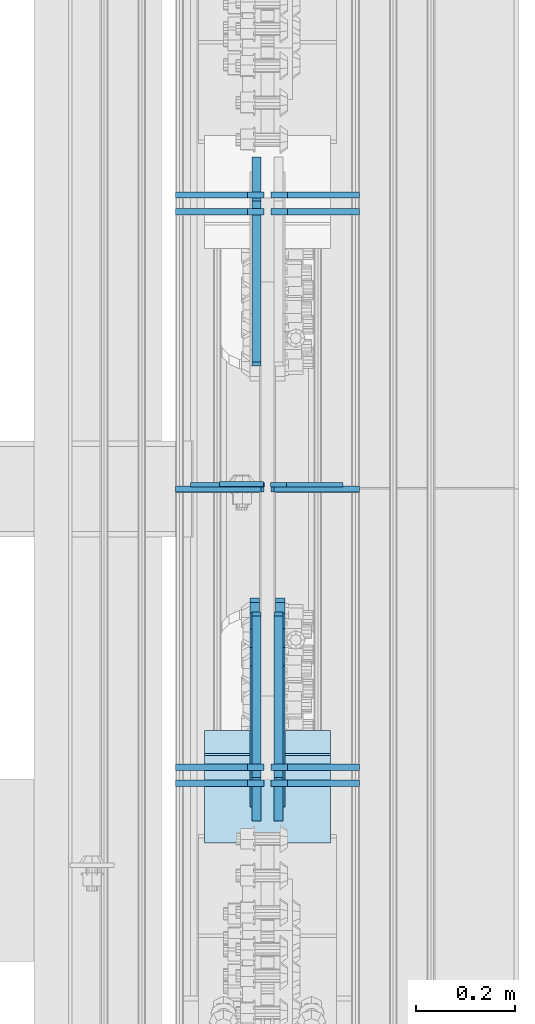
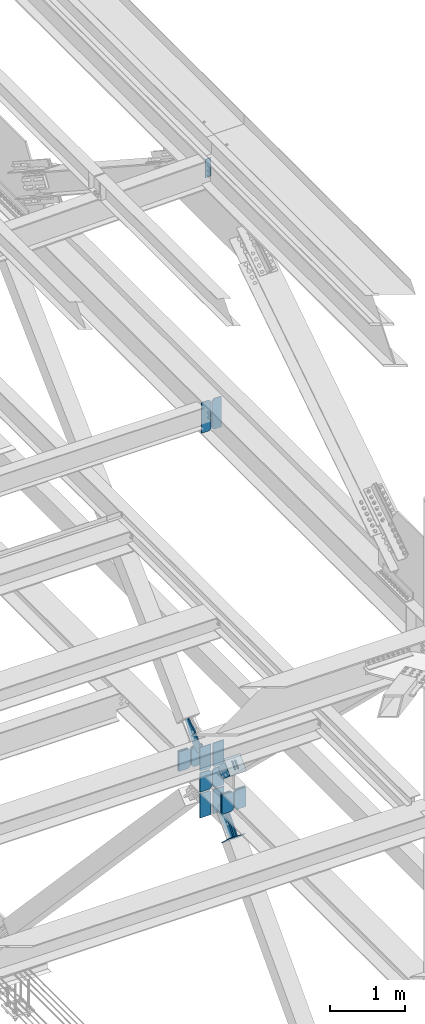
# One storey, part 3639 of 3843: 24 plates, 10 elements without a shape of their own.
"""IFC2X3 building model written with IfcOpenShell, lengths in millimetres."""

from ifc_helpers import new_model, si_unit, frame, origin_with_axes, place, context, subcontext, project, spatial, faceted_brep, material, type_object, element, aggregate, save


model = new_model("IFC2X3")

# Units and contexts
model_context = context("Model", 3, precision=1e-05, world=origin_with_axes())
body_context = subcontext(model_context, "Body", "Model", "MODEL_VIEW")
ifc_project = project(units=[si_unit("LENGTHUNIT", "METRE", prefix="MILLI"), si_unit("AREAUNIT", "SQUARE_METRE"), si_unit("VOLUMEUNIT", "CUBIC_METRE"), si_unit("MASSUNIT", "GRAM", prefix="KILO"), si_unit("TIMEUNIT", "SECOND"), si_unit("PLANEANGLEUNIT", "RADIAN"), si_unit("SOLIDANGLEUNIT", "STERADIAN"), si_unit("THERMODYNAMICTEMPERATUREUNIT", "DEGREE_CELSIUS"), si_unit("LUMINOUSINTENSITYUNIT", "LUMEN")], contexts=[model_context])

# Site, building, storey
site_placement = place(None, origin_with_axes())
site = spatial("IfcSite", under=ifc_project, at=site_placement, CompositionType="ELEMENT")
building_placement = place(site_placement, origin_with_axes())
building = spatial("IfcBuilding", under=site, at=building_placement, Name="Undefined", CompositionType="ELEMENT")
storey_placement = place(building_placement, origin_with_axes())
storey = spatial("IfcBuildingStorey", under=building, at=storey_placement, Name="Undefined", CompositionType="ELEMENT", Elevation=0.0)

# Assembly, plate
assembly_1_placement = place(storey_placement, origin_with_axes())
assembly_1 = element("IfcElementAssembly", 1, at=assembly_1_placement, inside=storey, Name="BEAM", AssemblyPlace="NOTDEFINED", PredefinedType="RIGID_FRAME")
ifc_material_1 = material(Name="STEEL/A572-50")
plate_type_1 = type_object("IfcPlateType", PredefinedType="NOTDEFINED")
plate_1_placement = place(assembly_1_placement, frame((85640.8624999999, 98397.21875, 46404.6717282419), z_axis=(-1.0, 0.0, 0.0), x_axis=(0.0, 0.0, -1.0)))
plate_1 = element("IfcPlate", 2, at=plate_1_placement, type_object=plate_type_1, material=ifc_material_1, Name="PLATE", context=body_context, shape_type="Brep", body=[
    faceted_brep([(0.0, -4.76249999999709, 0.0), (0.0, -4.76249999999709, 88.9000015258789), (0.0, 4.76249999999709, 88.9000015258789), (0.0, 4.76249999999709, 0.0), (304.800000000003, -4.76249999999709, 88.8999999999942), (304.800000000003, 4.76249999999709, 88.8999999999942), (304.800000000003, -4.76249999999709, 0.0), (304.800000000003, 4.76249999999709, 0.0)], [[[0, 1, 2, 3]], [[1, 4, 5, 2]], [[4, 6, 7, 5]], [[6, 0, 3, 7]], [[5, 7, 3, 2]], [[6, 4, 1, 0]]]),
])
aggregate(assembly_1, [plate_1])

assembly_2_placement = place(storey_placement, origin_with_axes())
assembly_2 = element("IfcElementAssembly", 3, at=assembly_2_placement, inside=storey, Name="BEAM", AssemblyPlace="NOTDEFINED", PredefinedType="RIGID_FRAME")
plate_type_2 = type_object("IfcPlateType", PredefinedType="NOTDEFINED")
plate_2_placement = place(assembly_2_placement, frame((85642.45, 98395.6318667901, 41946.5125), z_axis=(0.0, 0.0, 1.0), x_axis=(-1.0, 0.0, 0.0)))
plate_2 = element("IfcPlate", 4, at=plate_2_placement, type_object=plate_type_2, material=ifc_material_1, Name="PLATE", context=body_context, shape_type="Brep", body=[
    faceted_brep([(0.0, -4.76249999999709, 31.75), (0.0, -4.76250000000073, 469.900000000001), (0.0, 4.76250000000073, 469.900000000001), (0.0, 4.76249999999709, 31.75), (31.75, -4.76250000000073, 501.650000000001), (31.75, 4.76250000000073, 501.650000000001), (149.224999999991, -4.76250000000073, 501.650000000001), (149.224999999991, 4.76250000000073, 501.650000000001), (149.224999999977, -4.76249999999709, 0.0), (149.224999999977, 4.76249999999709, 0.0), (31.75, -4.76249999999709, 0.0), (31.75, 4.76249999999709, 0.0)], [[[0, 1, 2, 3]], [[1, 4, 5, 2]], [[4, 6, 7, 5]], [[6, 8, 9, 7]], [[8, 10, 11, 9]], [[10, 0, 3, 11]], [[5, 7, 9, 11, 3, 2]], [[10, 8, 6, 4, 1, 0]]]),
])

# Assembly, plates
assembly_3_placement = place(storey_placement, origin_with_axes())
assembly_3 = element("IfcElementAssembly", 5, at=assembly_3_placement, inside=storey, Name="BEAM", AssemblyPlace="NOTDEFINED", PredefinedType="RIGID_FRAME")
plate_type_3 = type_object("IfcPlateType", PredefinedType="NOTDEFINED")
plate_3_placement = place(assembly_3_placement, frame((85641.65625, 97792.7129254017, 36093.4), z_axis=(-1.0, 0.0, 0.0), x_axis=(0.0, 0.0, 1.0)))
plate_3 = element("IfcPlate", 6, at=plate_3_placement, type_object=plate_type_3, material=ifc_material_1, Name="CB_BEAM", context=body_context, shape_type="Brep", body=[
    faceted_brep([(0.0, -6.34999999999854, 33.3375015258789), (0.0, -6.34999999999854, 178.59375), (0.0, 6.34999999999854, 178.59375), (0.0, 6.34999999999854, 33.3375015258789), (317.499999999985, -6.34999999999854, 178.59375), (317.499999999985, 6.34999999999854, 178.59375), (317.499999999985, -6.34999999999854, 33.3375015258789), (317.499999999985, 6.34999999999854, 33.3375015258789), (284.162498474107, -6.34999999999854, 0.0), (284.162498474107, 6.34999999999854, 0.0), (33.3375015258789, -6.34999999999854, 0.0), (33.3375015258789, 6.34999999999854, 0.0)], [[[0, 1, 2, 3]], [[1, 4, 5, 2]], [[4, 6, 7, 5]], [[6, 8, 9, 7]], [[8, 10, 11, 9]], [[10, 0, 3, 11]], [[5, 7, 9, 11, 3, 2]], [[10, 8, 6, 4, 1, 0]]]),
])
plate_4_placement = place(assembly_3_placement, frame((85655.94375, 97792.7129254017, 36093.4), z_axis=(1.0, 0.0, 0.0), x_axis=(0.0, 0.0, 1.0)))
plate_4 = element("IfcPlate", 7, at=plate_4_placement, type_object=plate_type_3, material=ifc_material_1, Name="CB_BEAM", context=body_context, shape_type="Brep", body=[
    faceted_brep([(0.0, -6.34999999999854, 33.3375015258789), (0.0, -6.34999999999854, 178.59375), (0.0, 6.34999999999854, 178.59375), (0.0, 6.34999999999854, 33.3375015258789), (317.499999999985, -6.34999999999854, 178.59375), (317.499999999985, 6.34999999999854, 178.59375), (317.499999999985, -6.34999999999854, 33.3375015258789), (317.499999999985, 6.34999999999854, 33.3375015258789), (284.162498474107, -6.34999999999854, 0.0), (284.162498474107, 6.34999999999854, 0.0), (33.3375015258789, -6.34999999999854, 0.0), (33.3375015258789, 6.34999999999854, 0.0)], [[[0, 1, 2, 3]], [[1, 4, 5, 2]], [[4, 6, 7, 5]], [[6, 8, 9, 7]], [[8, 10, 11, 9]], [[10, 0, 3, 11]], [[5, 7, 9, 11, 3, 2]], [[10, 8, 6, 4, 1, 0]]]),
])
plate_5_placement = place(assembly_3_placement, frame((85641.65625, 97824.7372978455, 36093.4), z_axis=(-1.0, 0.0, 0.0), x_axis=(0.0, 0.0, 1.0)))
plate_5 = element("IfcPlate", 8, at=plate_5_placement, type_object=plate_type_3, material=ifc_material_1, Name="CB_BEAM", context=body_context, shape_type="Brep", body=[
    faceted_brep([(0.0, -6.34999999999854, 33.3375015258789), (0.0, -6.34999999999854, 178.59375), (0.0, 6.34999999999854, 178.59375), (0.0, 6.34999999999854, 33.3375015258789), (317.499999999985, -6.34999999999854, 178.59375), (317.499999999985, 6.34999999999854, 178.59375), (317.499999999985, -6.34999999999854, 33.3375015258789), (317.499999999985, 6.34999999999854, 33.3375015258789), (284.162498474107, -6.34999999999854, 0.0), (284.162498474107, 6.34999999999854, 0.0), (33.3375015258789, -6.34999999999854, 0.0), (33.3375015258789, 6.34999999999854, 0.0)], [[[0, 1, 2, 3]], [[1, 4, 5, 2]], [[4, 6, 7, 5]], [[6, 8, 9, 7]], [[8, 10, 11, 9]], [[10, 0, 3, 11]], [[5, 7, 9, 11, 3, 2]], [[10, 8, 6, 4, 1, 0]]]),
])
plate_6_placement = place(assembly_3_placement, frame((85655.94375, 97824.7372978455, 36093.4), z_axis=(1.0, 0.0, 0.0), x_axis=(0.0, 0.0, 1.0)))
plate_6 = element("IfcPlate", 9, at=plate_6_placement, type_object=plate_type_3, material=ifc_material_1, Name="CB_BEAM", context=body_context, shape_type="Brep", body=[
    faceted_brep([(0.0, -6.34999999999854, 33.3375015258789), (0.0, -6.34999999999854, 178.59375), (0.0, 6.34999999999854, 178.59375), (0.0, 6.34999999999854, 33.3375015258789), (317.499999999985, -6.34999999999854, 178.59375), (317.499999999985, 6.34999999999854, 178.59375), (317.499999999985, -6.34999999999854, 33.3375015258789), (317.499999999985, 6.34999999999854, 33.3375015258789), (284.162498474107, -6.34999999999854, 0.0), (284.162498474107, 6.34999999999854, 0.0), (33.3375015258789, -6.34999999999854, 0.0), (33.3375015258789, 6.34999999999854, 0.0)], [[[0, 1, 2, 3]], [[1, 4, 5, 2]], [[4, 6, 7, 5]], [[6, 8, 9, 7]], [[8, 10, 11, 9]], [[10, 0, 3, 11]], [[5, 7, 9, 11, 3, 2]], [[10, 8, 6, 4, 1, 0]]]),
])
plate_7_placement = place(assembly_3_placement, frame((85641.65625, 98947.4717351589, 36093.4), z_axis=(-1.0, 0.0, 0.0), x_axis=(0.0, 0.0, 1.0)))
plate_7 = element("IfcPlate", 10, at=plate_7_placement, type_object=plate_type_3, material=ifc_material_1, Name="CB_BEAM", context=body_context, shape_type="Brep", body=[
    faceted_brep([(0.0, -6.34999999999854, 33.3375015258789), (0.0, -6.34999999999854, 178.59375), (0.0, 6.34999999999854, 178.59375), (0.0, 6.34999999999854, 33.3375015258789), (317.499999999985, -6.34999999999854, 178.59375), (317.499999999985, 6.34999999999854, 178.59375), (317.499999999985, -6.34999999999854, 33.3375015258789), (317.499999999985, 6.34999999999854, 33.3375015258789), (284.162498474107, -6.34999999999854, 0.0), (284.162498474107, 6.34999999999854, 0.0), (33.3375015258789, -6.34999999999854, 0.0), (33.3375015258789, 6.34999999999854, 0.0)], [[[0, 1, 2, 3]], [[1, 4, 5, 2]], [[4, 6, 7, 5]], [[6, 8, 9, 7]], [[8, 10, 11, 9]], [[10, 0, 3, 11]], [[5, 7, 9, 11, 3, 2]], [[10, 8, 6, 4, 1, 0]]]),
])
plate_8_placement = place(assembly_3_placement, frame((85655.94375, 98947.4717351589, 36093.4), z_axis=(1.0, 0.0, 0.0), x_axis=(0.0, 0.0, 1.0)))
plate_8 = element("IfcPlate", 11, at=plate_8_placement, type_object=plate_type_3, material=ifc_material_1, Name="CB_BEAM", context=body_context, shape_type="Brep", body=[
    faceted_brep([(0.0, -6.34999999999854, 33.3375015258789), (0.0, -6.34999999999854, 178.59375), (0.0, 6.34999999999854, 178.59375), (0.0, 6.34999999999854, 33.3375015258789), (317.499999999985, -6.34999999999854, 178.59375), (317.499999999985, 6.34999999999854, 178.59375), (317.499999999985, -6.34999999999854, 33.3375015258789), (317.499999999985, 6.34999999999854, 33.3375015258789), (284.162498474107, -6.34999999999854, 0.0), (284.162498474107, 6.34999999999854, 0.0), (33.3375015258789, -6.34999999999854, 0.0), (33.3375015258789, 6.34999999999854, 0.0)], [[[0, 1, 2, 3]], [[1, 4, 5, 2]], [[4, 6, 7, 5]], [[6, 8, 9, 7]], [[8, 10, 11, 9]], [[10, 0, 3, 11]], [[5, 7, 9, 11, 3, 2]], [[10, 8, 6, 4, 1, 0]]]),
])
plate_9_placement = place(assembly_3_placement, frame((85641.65625, 98981.1728706821, 36093.4), z_axis=(-1.0, 0.0, 0.0), x_axis=(0.0, 0.0, 1.0)))
plate_9 = element("IfcPlate", 12, at=plate_9_placement, type_object=plate_type_3, material=ifc_material_1, Name="CB_BEAM", context=body_context, shape_type="Brep", body=[
    faceted_brep([(0.0, -6.34999999999854, 33.3375015258789), (0.0, -6.34999999999854, 178.59375), (0.0, 6.34999999999854, 178.59375), (0.0, 6.34999999999854, 33.3375015258789), (317.499999999985, -6.34999999999854, 178.59375), (317.499999999985, 6.34999999999854, 178.59375), (317.499999999985, -6.34999999999854, 33.3375015258789), (317.499999999985, 6.34999999999854, 33.3375015258789), (284.162498474107, -6.34999999999854, 0.0), (284.162498474107, 6.34999999999854, 0.0), (33.3375015258789, -6.34999999999854, 0.0), (33.3375015258789, 6.34999999999854, 0.0)], [[[0, 1, 2, 3]], [[1, 4, 5, 2]], [[4, 6, 7, 5]], [[6, 8, 9, 7]], [[8, 10, 11, 9]], [[10, 0, 3, 11]], [[5, 7, 9, 11, 3, 2]], [[10, 8, 6, 4, 1, 0]]]),
])
plate_10_placement = place(assembly_3_placement, frame((85655.94375, 98981.1728706821, 36093.4), z_axis=(1.0, 0.0, 0.0), x_axis=(0.0, 0.0, 1.0)))
plate_10 = element("IfcPlate", 13, at=plate_10_placement, type_object=plate_type_3, material=ifc_material_1, Name="CB_BEAM", context=body_context, shape_type="Brep", body=[
    faceted_brep([(0.0, -6.34999999999854, 33.3375015258789), (0.0, -6.34999999999854, 178.59375), (0.0, 6.34999999999854, 178.59375), (0.0, 6.34999999999854, 33.3375015258789), (317.499999999985, -6.34999999999854, 178.59375), (317.499999999985, 6.34999999999854, 178.59375), (317.499999999985, -6.34999999999854, 33.3375015258789), (317.499999999985, 6.34999999999854, 33.3375015258789), (284.162498474107, -6.34999999999854, 0.0), (284.162498474107, 6.34999999999854, 0.0), (33.3375015258789, -6.34999999999854, 0.0), (33.3375015258789, 6.34999999999854, 0.0)], [[[0, 1, 2, 3]], [[1, 4, 5, 2]], [[4, 6, 7, 5]], [[6, 8, 9, 7]], [[8, 10, 11, 9]], [[10, 0, 3, 11]], [[5, 7, 9, 11, 3, 2]], [[10, 8, 6, 4, 1, 0]]]),
])
plate_11_placement = place(assembly_3_placement, frame((85641.65625, 98386.9445868708, 36093.4), z_axis=(-1.0, 0.0, 0.0), x_axis=(0.0, 0.0, 1.0)))
plate_11 = element("IfcPlate", 14, at=plate_11_placement, type_object=plate_type_3, material=ifc_material_1, Name="CB_BEAM", context=body_context, shape_type="Brep", body=[
    faceted_brep([(0.0, -6.34999999999854, 33.3375015258789), (0.0, -6.34999999999854, 178.59375), (0.0, 6.34999999999854, 178.59375), (0.0, 6.34999999999854, 33.3375015258789), (317.499999999985, -6.34999999999854, 178.59375), (317.499999999985, 6.34999999999854, 178.59375), (317.499999999985, -6.34999999999854, 33.3375015258789), (317.499999999985, 6.34999999999854, 33.3375015258789), (284.162498474107, -6.34999999999854, 0.0), (284.162498474107, 6.34999999999854, 0.0), (33.3375015258789, -6.34999999999854, 0.0), (33.3375015258789, 6.34999999999854, 0.0)], [[[0, 1, 2, 3]], [[1, 4, 5, 2]], [[4, 6, 7, 5]], [[6, 8, 9, 7]], [[8, 10, 11, 9]], [[10, 0, 3, 11]], [[5, 7, 9, 11, 3, 2]], [[10, 8, 6, 4, 1, 0]]]),
])
plate_12_placement = place(assembly_3_placement, frame((85655.94375, 98386.9445868708, 36093.4), z_axis=(1.0, 0.0, 0.0), x_axis=(0.0, 0.0, 1.0)))
plate_12 = element("IfcPlate", 15, at=plate_12_placement, type_object=plate_type_3, material=ifc_material_1, Name="CB_BEAM", context=body_context, shape_type="Brep", body=[
    faceted_brep([(0.0, -6.34999999999854, 33.3375015258789), (0.0, -6.34999999999854, 178.59375), (0.0, 6.34999999999854, 178.59375), (0.0, 6.34999999999854, 33.3375015258789), (317.499999999985, -6.34999999999854, 178.59375), (317.499999999985, 6.34999999999854, 178.59375), (317.499999999985, -6.34999999999854, 33.3375015258789), (317.499999999985, 6.34999999999854, 33.3375015258789), (284.162498474107, -6.34999999999854, 0.0), (284.162498474107, 6.34999999999854, 0.0), (33.3375015258789, -6.34999999999854, 0.0), (33.3375015258789, 6.34999999999854, 0.0)], [[[0, 1, 2, 3]], [[1, 4, 5, 2]], [[4, 6, 7, 5]], [[6, 8, 9, 7]], [[8, 10, 11, 9]], [[10, 0, 3, 11]], [[5, 7, 9, 11, 3, 2]], [[10, 8, 6, 4, 1, 0]]]),
])

# Plate
plate_type_4 = type_object("IfcPlateType", PredefinedType="NOTDEFINED")
plate_13_placement = place(assembly_2_placement, frame((85655.15, 98395.63186679, 41946.5125), z_axis=(0.0, 0.0, 1.0), x_axis=(1.0, 0.0, 0.0)))
plate_13 = element("IfcPlate", 16, at=plate_13_placement, type_object=plate_type_4, material=ifc_material_1, Name="PLATE", context=body_context, shape_type="Brep", body=[
    faceted_brep([(0.0, -4.76249999999709, 31.75), (0.0, -4.76250000000073, 469.900000000001), (0.0, 4.76250000000073, 469.900000000001), (0.0, 4.76249999999709, 31.75), (31.75, -4.76250000000073, 501.650000000001), (31.75, 4.76250000000073, 501.650000000001), (146.049999999988, -4.76250000000073, 501.650000000001), (146.049999999988, 4.76250000000073, 501.650000000001), (146.049999999988, -4.76250000000073, 0.0), (146.049999999988, 4.76250000000073, 0.0), (31.75, -4.76249999999709, 0.0), (31.75, 4.76249999999709, 0.0)], [[[0, 1, 2, 3]], [[1, 4, 5, 2]], [[4, 6, 7, 5]], [[6, 8, 9, 7]], [[8, 10, 11, 9]], [[10, 0, 3, 11]], [[5, 7, 9, 11, 3, 2]], [[10, 8, 6, 4, 1, 0]]]),
])

aggregate(assembly_2, [plate_13, plate_2])

plate_type_5 = type_object("IfcPlateType", PredefinedType="NOTDEFINED")
plate_14_placement = place(assembly_3_placement, frame((85636.1, 98386.9445868708, 36436.3), z_axis=(-1.0, 0.0, 0.0), x_axis=(0.0, 0.0, 1.0)))
plate_14 = element("IfcPlate", 17, at=plate_14_placement, type_object=plate_type_5, material=ifc_material_1, Name="CB", context=body_context, shape_type="Brep", body=[
    faceted_brep([(0.0, -6.34999999999854, 19.0499992370605), (0.0, -6.34999999999854, 173.037500000006), (0.0, 6.34999999999854, 173.037500000006), (0.0, 6.34999999999854, 19.0499992370605), (388.479528461168, -6.35000000000582, 173.037500000006), (388.479528461168, 6.35000000000582, 173.037500000006), (388.479528461168, -6.35000000000582, 0.0), (388.479528461168, 6.35000000000582, 0.0), (19.0499992370605, -6.34999999999854, 0.0), (19.0499992370605, 6.34999999999854, 0.0)], [[[0, 1, 2, 3]], [[1, 4, 5, 2]], [[4, 6, 7, 5]], [[6, 8, 9, 7]], [[8, 0, 3, 9]], [[5, 7, 9, 3, 2]], [[8, 6, 4, 1, 0]]]),
])

plate_15_placement = place(assembly_3_placement, frame((85661.5, 98386.9445868708, 36436.3), z_axis=(1.0, 0.0, 0.0), x_axis=(0.0, 0.0, 1.0)))
plate_15 = element("IfcPlate", 18, at=plate_15_placement, type_object=plate_type_5, material=ifc_material_1, Name="CB", context=body_context, shape_type="Brep", body=[
    faceted_brep([(0.0, -6.34999999999854, 19.0499992370605), (0.0, -6.34999999999854, 173.037500000006), (0.0, 6.34999999999854, 173.037500000006), (0.0, 6.34999999999854, 19.0499992370605), (388.479528461168, -6.35000000000582, 173.037500000006), (388.479528461168, 6.35000000000582, 173.037500000006), (388.479528461168, -6.35000000000582, 0.0), (388.479528461168, 6.35000000000582, 0.0), (19.0499992370605, -6.34999999999854, 0.0), (19.0499992370605, 6.34999999999854, 0.0)], [[[0, 1, 2, 3]], [[1, 4, 5, 2]], [[4, 6, 7, 5]], [[6, 8, 9, 7]], [[8, 0, 3, 9]], [[5, 7, 9, 3, 2]], [[8, 6, 4, 1, 0]]]),
])

# Assembly, plate
assembly_4_placement = place(storey_placement, origin_with_axes())
assembly_4 = element("IfcElementAssembly", 19, at=assembly_4_placement, inside=storey, AssemblyPlace="NOTDEFINED", PredefinedType="RIGID_FRAME")
ifc_material_2 = material(Name="STEEL/A36")
plate_type_6 = type_object("IfcPlateType", PredefinedType="NOTDEFINED")
plate_16_placement = place(assembly_4_placement, frame((85626.575, 99007.2583249382, 36761.4812447326), z_axis=(0.0, -0.693740529148912, 0.720225019154561), x_axis=(0.0, 0.720225019154586, 0.693740529148886)))
plate_16 = element("IfcPlate", 20, at=plate_16_placement, type_object=plate_type_6, material=ifc_material_2, context=body_context, shape_type="Brep", body=[
    faceted_brep([(0.0, -9.52500000000146, 0.0), (-101.599999996755, -9.52499999999418, -33.324272213511), (-101.599999996755, 9.52499999999418, -33.324272213511), (0.0, 9.52500000000146, 0.0), (-320.279297653902, -9.52499999999418, -33.3242722122595), (-320.279297653902, 9.52499999999418, -33.3242722122595), (-357.337405119242, -9.52499999999418, -25.9529563255783), (-357.337405119242, 9.52499999999418, -25.9529563255783), (-388.753751655597, -9.52499999999418, -4.96122468852991), (-388.753751655597, 9.52499999999418, -4.96122468852991), (-409.745483292782, -9.52499999999418, 26.4551218477136), (-409.745483292782, 9.52499999999418, 26.4551218477136), (-417.116799179586, -9.52499999999418, 63.5132262653569), (-417.116799179586, 9.52499999999418, 63.5132262653569), (-409.745483293211, -9.52499999999418, 100.57133373119), (-409.745483293211, 9.52499999999418, 100.57133373119), (-388.753751656006, -9.52499999999418, 131.987680267928), (-388.753751656006, 9.52499999999418, 131.987680267928), (-357.337405119271, -9.52499999999418, 152.97941190518), (-357.337405119271, 9.52499999999418, 152.97941190518), (-320.279299183247, -9.52499999999418, 160.350727791658), (-320.279299183247, 9.52499999999418, 160.350727791658), (-101.599999998418, -9.52499999999418, 160.350727790414), (-101.599999998418, 9.52499999999418, 160.350727790414), (-1.04046193882823e-09, -9.52499999999418, 127.02645557576), (-1.04046193882823e-09, 9.52499999999418, 127.02645557576), (69.8499999968899, -9.52499999999418, 127.026455575353), (69.8499999968899, 9.52499999999418, 127.026455575353), (69.8499999979995, -9.52499999999418, -4.00177668780088e-10), (69.8499999979995, 9.52499999999418, -4.00177668780088e-10)], [[[0, 1, 2, 3]], [[1, 4, 5, 2]], [[4, 6, 7, 5]], [[6, 8, 9, 7]], [[8, 10, 11, 9]], [[10, 12, 13, 11]], [[12, 14, 15, 13]], [[14, 16, 17, 15]], [[16, 18, 19, 17]], [[18, 20, 21, 19]], [[20, 22, 23, 21]], [[22, 24, 25, 23]], [[24, 26, 27, 25]], [[26, 28, 29, 27]], [[28, 0, 3, 29]], [[5, 7, 9, 11, 13, 15, 17, 19, 21, 23, 25, 27, 29, 3, 2]], [[28, 26, 24, 22, 20, 18, 16, 14, 12, 10, 8, 6, 4, 1, 0]]]),
])
aggregate(assembly_4, [plate_16])

assembly_5_placement = place(storey_placement, origin_with_axes())
assembly_5 = element("IfcElementAssembly", 21, at=assembly_5_placement, inside=storey, AssemblyPlace="NOTDEFINED", PredefinedType="RIGID_FRAME")
plate_17_placement = place(assembly_5_placement, frame((85626.575, 97804.4410013858, 36901.4216904141), z_axis=(0.0, -0.693734394323864, -0.720230928336253), x_axis=(0.0, 0.720230928336252, -0.693734394323865)))
plate_17 = element("IfcPlate", 22, at=plate_17_placement, type_object=plate_type_6, material=ifc_material_2, context=body_context, shape_type="Brep", body=[
    faceted_brep([(0.0, -9.52500000000146, 0.0), (-1.04046193882823e-09, -9.52499999999418, 127.02645557576), (-1.04046193882823e-09, 9.52499999999418, 127.02645557576), (0.0, 9.52500000000146, 0.0), (69.8499999968899, -9.52499999999418, 127.026455575353), (69.8499999968899, 9.52499999999418, 127.026455575353), (171.449999994144, -9.52499999999418, 160.350727789177), (171.449999994144, 9.52499999999418, 160.350727789177), (390.129297651329, -9.52499999999418, 160.350727787925), (390.129297651329, 9.52499999999418, 160.350727787925), (427.187405116643, -9.52499999999418, 152.979411901222), (427.187405116643, 9.52499999999418, 152.979411901222), (458.603751652932, -9.52499999999418, 131.987680264123), (458.603751652932, 9.52499999999418, 131.987680264123), (479.595483290015, -9.52499999999418, 100.571333727821), (479.595483290015, 9.52499999999418, 100.571333727821), (486.966799176706, -9.52499999999418, 63.5132293100978), (486.966799176706, 9.52499999999418, 63.5132293100978), (479.595483290208, -9.52499999999418, 26.4551218441993), (479.595483290208, 9.52499999999418, 26.4551218441993), (458.603751652907, -9.52499999999418, -4.96122469259717), (458.603751652907, 9.52499999999418, -4.96122469259717), (427.187405116098, -9.52499999999418, -25.9529563298856), (427.187405116098, 9.52499999999418, -25.9529563298856), (390.129299180044, -9.52499999999418, -33.3242722163704), (390.129299180044, 9.52499999999418, -33.3242722163704), (171.449999995208, -9.52499999999418, -33.3242722151044), (171.449999995208, 9.52499999999418, -33.3242722151044), (69.8499999979995, -9.52499999999418, -4.00177668780088e-10), (69.8499999979995, 9.52499999999418, -4.00177668780088e-10)], [[[0, 1, 2, 3]], [[1, 4, 5, 2]], [[4, 6, 7, 5]], [[6, 8, 9, 7]], [[8, 10, 11, 9]], [[10, 12, 13, 11]], [[12, 14, 15, 13]], [[14, 16, 17, 15]], [[16, 18, 19, 17]], [[18, 20, 21, 19]], [[20, 22, 23, 21]], [[22, 24, 25, 23]], [[24, 26, 27, 25]], [[26, 28, 29, 27]], [[28, 0, 3, 29]], [[5, 7, 9, 11, 13, 15, 17, 19, 21, 23, 25, 27, 29, 3, 2]], [[28, 26, 24, 22, 20, 18, 16, 14, 12, 10, 8, 6, 4, 1, 0]]]),
])
aggregate(assembly_5, [plate_17])

assembly_6_placement = place(storey_placement, origin_with_axes())
assembly_6 = element("IfcElementAssembly", 23, at=assembly_6_placement, inside=storey, AssemblyPlace="NOTDEFINED", PredefinedType="RIGID_FRAME")
plate_18_placement = place(assembly_6_placement, frame((85671.025, 97804.4410013858, 36901.4216904141), z_axis=(0.0, -0.693734394323864, -0.720230928336253), x_axis=(0.0, 0.720230928336252, -0.693734394323865)))
plate_18 = element("IfcPlate", 24, at=plate_18_placement, type_object=plate_type_6, material=ifc_material_2, context=body_context, shape_type="Brep", body=[
    faceted_brep([(0.0, -9.52500000000146, 0.0), (-1.04046193882823e-09, -9.52499999999418, 127.02645557576), (-1.04046193882823e-09, 9.52499999999418, 127.02645557576), (0.0, 9.52500000000146, 0.0), (69.8499999968899, -9.52499999999418, 127.026455575353), (69.8499999968899, 9.52499999999418, 127.026455575353), (171.449999994144, -9.52499999999418, 160.350727789177), (171.449999994144, 9.52499999999418, 160.350727789177), (390.129297651329, -9.52499999999418, 160.350727787925), (390.129297651329, 9.52499999999418, 160.350727787925), (427.187405116643, -9.52499999999418, 152.979411901222), (427.187405116643, 9.52499999999418, 152.979411901222), (458.603751652932, -9.52499999999418, 131.987680264123), (458.603751652932, 9.52499999999418, 131.987680264123), (479.595483290015, -9.52499999999418, 100.571333727821), (479.595483290015, 9.52499999999418, 100.571333727821), (486.966799176706, -9.52499999999418, 63.5132293100978), (486.966799176706, 9.52499999999418, 63.5132293100978), (479.595483290208, -9.52499999999418, 26.4551218441993), (479.595483290208, 9.52499999999418, 26.4551218441993), (458.603751652907, -9.52499999999418, -4.96122469259717), (458.603751652907, 9.52499999999418, -4.96122469259717), (427.187405116098, -9.52499999999418, -25.9529563298856), (427.187405116098, 9.52499999999418, -25.9529563298856), (390.129299180044, -9.52499999999418, -33.3242722163704), (390.129299180044, 9.52499999999418, -33.3242722163704), (171.449999995208, -9.52499999999418, -33.3242722151044), (171.449999995208, 9.52499999999418, -33.3242722151044), (69.8499999979995, -9.52499999999418, -4.00177668780088e-10), (69.8499999979995, 9.52499999999418, -4.00177668780088e-10)], [[[0, 1, 2, 3]], [[1, 4, 5, 2]], [[4, 6, 7, 5]], [[6, 8, 9, 7]], [[8, 10, 11, 9]], [[10, 12, 13, 11]], [[12, 14, 15, 13]], [[14, 16, 17, 15]], [[16, 18, 19, 17]], [[18, 20, 21, 19]], [[20, 22, 23, 21]], [[22, 24, 25, 23]], [[24, 26, 27, 25]], [[26, 28, 29, 27]], [[28, 0, 3, 29]], [[5, 7, 9, 11, 13, 15, 17, 19, 21, 23, 25, 27, 29, 3, 2]], [[28, 26, 24, 22, 20, 18, 16, 14, 12, 10, 8, 6, 4, 1, 0]]]),
])
aggregate(assembly_6, [plate_18])

assembly_7_placement = place(storey_placement, origin_with_axes())
assembly_7 = element("IfcElementAssembly", 25, at=assembly_7_placement, inside=storey, AssemblyPlace="NOTDEFINED", PredefinedType="RIGID_FRAME")
plate_19_placement = place(assembly_7_placement, frame((85623.4, 97860.5517164785, 35575.9982973555), z_axis=(0.0, -0.728943917919311, 0.684573417924218), x_axis=(0.0, 0.684573417924221, 0.728943917919308)))
plate_19 = element("IfcPlate", 26, at=plate_19_placement, type_object=plate_type_6, material=ifc_material_2, context=body_context, shape_type="Brep", body=[
    faceted_brep([(0.0, -9.52500000000146, 0.0), (1.71894498635083e-09, -9.52499999999418, 158.39421297863), (1.71894498635083e-09, 9.52499999999418, 158.39421297863), (0.0, 9.52500000000146, 0.0), (69.8500000010408, -9.52499999999418, 158.394212979103), (69.8500000010408, 9.52499999999418, 158.394212979103), (171.450000002631, -9.52499999999418, 176.034606488582), (171.450000002631, 9.52499999999418, 176.034606488582), (390.129297671807, -9.52499999999418, 176.034606487716), (390.129297671807, 9.52499999999418, 176.034606487716), (427.187405137312, -9.52499999999418, 168.663290600991), (427.187405137312, 9.52499999999418, 168.663290600991), (458.60375167372, -9.52499999999418, 147.671558963724), (458.60375167372, 9.52499999999418, 147.671558963724), (479.59548331075, -9.52499999999418, 116.255212427161), (479.59548331075, 9.52499999999418, 116.255212427161), (486.966799197198, -9.52499999999418, 79.1971080138683), (486.966799197198, 9.52499999999418, 79.1971080138683), (479.595483310488, -9.52499999999418, 42.1390005483336), (479.595483310488, 9.52499999999418, 42.1390005483336), (458.603751673207, -9.52499999999418, 10.7226540119082), (458.603751673207, 9.52499999999418, 10.7226540119082), (427.18740513661, -9.52499999999418, -10.2690776251402), (427.18740513661, 9.52499999999418, -10.2690776251402), (390.129299195723, -9.52499999999418, -17.6403935115741), (390.129299195723, 9.52499999999418, -17.6403935115741), (171.450000001962, -9.52499999999418, -17.6403935107155), (171.450000001962, 9.52499999999418, -17.6403935107155), (69.8499999979995, -9.52499999999418, -4.00177668780088e-10), (69.8499999979995, 9.52499999999418, -4.00177668780088e-10)], [[[0, 1, 2, 3]], [[1, 4, 5, 2]], [[4, 6, 7, 5]], [[6, 8, 9, 7]], [[8, 10, 11, 9]], [[10, 12, 13, 11]], [[12, 14, 15, 13]], [[14, 16, 17, 15]], [[16, 18, 19, 17]], [[18, 20, 21, 19]], [[20, 22, 23, 21]], [[22, 24, 25, 23]], [[24, 26, 27, 25]], [[26, 28, 29, 27]], [[28, 0, 3, 29]], [[5, 7, 9, 11, 13, 15, 17, 19, 21, 23, 25, 27, 29, 3, 2]], [[28, 26, 24, 22, 20, 18, 16, 14, 12, 10, 8, 6, 4, 1, 0]]]),
])
aggregate(assembly_7, [plate_19])

assembly_8_placement = place(storey_placement, origin_with_axes())
assembly_8 = element("IfcElementAssembly", 27, at=assembly_8_placement, inside=storey, AssemblyPlace="NOTDEFINED", PredefinedType="RIGID_FRAME")
plate_20_placement = place(assembly_8_placement, frame((85674.2, 97860.5517164785, 35575.9982973555), z_axis=(0.0, -0.728943917919311, 0.684573417924218), x_axis=(0.0, 0.684573417924221, 0.728943917919308)))
plate_20 = element("IfcPlate", 28, at=plate_20_placement, type_object=plate_type_6, material=ifc_material_2, context=body_context, shape_type="Brep", body=[
    faceted_brep([(0.0, -9.52500000000146, 0.0), (1.71894498635083e-09, -9.52499999999418, 158.39421297863), (1.71894498635083e-09, 9.52499999999418, 158.39421297863), (0.0, 9.52500000000146, 0.0), (69.8500000010408, -9.52499999999418, 158.394212979103), (69.8500000010408, 9.52499999999418, 158.394212979103), (171.450000002631, -9.52499999999418, 176.034606488582), (171.450000002631, 9.52499999999418, 176.034606488582), (390.129297671807, -9.52499999999418, 176.034606487716), (390.129297671807, 9.52499999999418, 176.034606487716), (427.187405137312, -9.52499999999418, 168.663290600991), (427.187405137312, 9.52499999999418, 168.663290600991), (458.60375167372, -9.52499999999418, 147.671558963724), (458.60375167372, 9.52499999999418, 147.671558963724), (479.59548331075, -9.52499999999418, 116.255212427161), (479.59548331075, 9.52499999999418, 116.255212427161), (486.966799197198, -9.52499999999418, 79.1971080138683), (486.966799197198, 9.52499999999418, 79.1971080138683), (479.595483310488, -9.52499999999418, 42.1390005483336), (479.595483310488, 9.52499999999418, 42.1390005483336), (458.603751673207, -9.52499999999418, 10.7226540119082), (458.603751673207, 9.52499999999418, 10.7226540119082), (427.18740513661, -9.52499999999418, -10.2690776251402), (427.18740513661, 9.52499999999418, -10.2690776251402), (390.129299195723, -9.52499999999418, -17.6403935115741), (390.129299195723, 9.52499999999418, -17.6403935115741), (171.450000001962, -9.52499999999418, -17.6403935107155), (171.450000001962, 9.52499999999418, -17.6403935107155), (69.8499999979995, -9.52499999999418, -4.00177668780088e-10), (69.8499999979995, 9.52499999999418, -4.00177668780088e-10)], [[[0, 1, 2, 3]], [[1, 4, 5, 2]], [[4, 6, 7, 5]], [[6, 8, 9, 7]], [[8, 10, 11, 9]], [[10, 12, 13, 11]], [[12, 14, 15, 13]], [[14, 16, 17, 15]], [[16, 18, 19, 17]], [[18, 20, 21, 19]], [[20, 22, 23, 21]], [[22, 24, 25, 23]], [[24, 26, 27, 25]], [[26, 28, 29, 27]], [[28, 0, 3, 29]], [[5, 7, 9, 11, 13, 15, 17, 19, 21, 23, 25, 27, 29, 3, 2]], [[28, 26, 24, 22, 20, 18, 16, 14, 12, 10, 8, 6, 4, 1, 0]]]),
])
aggregate(assembly_8, [plate_20])

assembly_9_placement = place(storey_placement, origin_with_axes())
assembly_9 = element("IfcElementAssembly", 29, at=assembly_9_placement, inside=storey, Name="Plate", AssemblyPlace="NOTDEFINED", PredefinedType="RIGID_FRAME")
plate_type_7 = type_object("IfcPlateType", PredefinedType="NOTDEFINED")
plate_21_placement = place(assembly_9_placement, frame((85521.8, 97674.5621558365, 36762.0055647294), z_axis=(0.0, 0.693734394323883, 0.720230928336235), x_axis=(1.0, 0.0, 0.0)))
plate_21 = element("IfcPlate", 30, at=plate_21_placement, type_object=plate_type_7, material=ifc_material_2, Name="Plate", context=body_context, shape_type="Brep", body=[
    faceted_brep([(0.0, -3.17499999999927, 0.0), (0.0, -3.17499999965185, 254.000000005151), (0.0, 3.17500000035216, 254.000000005166), (0.0, 3.17499999999927, 0.0), (254.0, -3.17499999965185, 254.000000005151), (254.0, 3.17500000035216, 254.000000005166), (254.0, -3.17500000000291, 0.0), (254.0, 3.17499999999927, 1.45519152283669e-11)], [[[0, 1, 2, 3]], [[1, 4, 5, 2]], [[4, 6, 7, 5]], [[6, 0, 3, 7]], [[5, 7, 3, 2]], [[6, 4, 1, 0]]]),
])
aggregate(assembly_9, [plate_21])

assembly_10_placement = place(storey_placement, origin_with_axes())
assembly_10 = element("IfcElementAssembly", 31, at=assembly_10_placement, inside=storey, Name="Plate", AssemblyPlace="NOTDEFINED", PredefinedType="RIGID_FRAME")
plate_22_placement = place(assembly_10_placement, frame((85775.8, 97897.5708655959, 35545.5881040992), z_axis=(0.0, -0.728943917919311, 0.684573417924218), x_axis=(-1.0, 0.0, 0.0)))
plate_22 = element("IfcPlate", 32, at=plate_22_placement, type_object=plate_type_7, material=ifc_material_2, Name="Plate", context=body_context, shape_type="Brep", body=[
    faceted_brep([(0.0, -3.17499999999927, 0.0), (0.0, -3.17499999965185, 254.000000005151), (0.0, 3.17500000035216, 254.000000005166), (0.0, 3.17499999999927, 0.0), (254.0, -3.17499999965185, 254.000000005151), (254.0, 3.17500000035216, 254.000000005166), (254.0, -3.17500000000291, 0.0), (254.0, 3.17499999999927, 1.45519152283669e-11)], [[[0, 1, 2, 3]], [[1, 4, 5, 2]], [[4, 6, 7, 5]], [[6, 0, 3, 7]], [[5, 7, 3, 2]], [[6, 4, 1, 0]]]),
])
aggregate(assembly_10, [plate_22])

# Plate
plate_type_8 = type_object("IfcPlateType", PredefinedType="NOTDEFINED")
plate_23_placement = place(assembly_3_placement, frame((85632.925, 98386.899994269, 35671.521875), z_axis=(-1.0, 0.0, 0.0), x_axis=(0.0, 0.0, 1.0)))
plate_23 = element("IfcPlate", 33, at=plate_23_placement, type_object=plate_type_8, material=ifc_material_1, Name="CB", context=body_context, shape_type="Brep", body=[
    faceted_brep([(0.0, -6.3499999046162, 0.0), (0.0, -6.35000000000582, 169.862500000003), (0.0, 6.35000000000582, 169.862500000003), (7.27595761418343e-12, 6.3499999046162, 0.0), (396.488577264769, -6.35000000000582, 169.862500000003), (396.488577264769, 6.35000000000582, 169.862500000003), (396.488577264769, -6.35000000000582, 19.0499992370605), (396.488577264769, 6.35000000000582, 19.0499992370605), (377.438578027708, -6.35000000000582, 0.0), (377.438578027708, 6.35000000000582, 0.0)], [[[0, 1, 2, 3]], [[1, 4, 5, 2]], [[4, 6, 7, 5]], [[6, 8, 9, 7]], [[8, 0, 3, 9]], [[5, 7, 9, 3, 2]], [[8, 6, 4, 1, 0]]]),
])

plate_24_placement = place(assembly_3_placement, frame((85664.675, 98386.899994269, 35671.521875), z_axis=(1.0, 0.0, 0.0), x_axis=(0.0, 0.0, 1.0)))
plate_24 = element("IfcPlate", 34, at=plate_24_placement, type_object=plate_type_8, material=ifc_material_1, Name="CB", context=body_context, shape_type="Brep", body=[
    faceted_brep([(0.0, -6.3499999046162, 0.0), (0.0, -6.35000000000582, 169.862500000003), (0.0, 6.35000000000582, 169.862500000003), (7.27595761418343e-12, 6.3499999046162, 0.0), (396.488577264769, -6.35000000000582, 169.862500000003), (396.488577264769, 6.35000000000582, 169.862500000003), (396.488577264769, -6.35000000000582, 19.0499992370605), (396.488577264769, 6.35000000000582, 19.0499992370605), (377.438578027708, -6.35000000000582, 0.0), (377.438578027708, 6.35000000000582, 0.0)], [[[0, 1, 2, 3]], [[1, 4, 5, 2]], [[4, 6, 7, 5]], [[6, 8, 9, 7]], [[8, 0, 3, 9]], [[5, 7, 9, 3, 2]], [[8, 6, 4, 1, 0]]]),
])

aggregate(assembly_3, [plate_3, plate_4, plate_5, plate_6, plate_7, plate_8, plate_9, plate_10, plate_11, plate_14, plate_15, plate_12, plate_23, plate_24])

save(model, "model.ifc")
